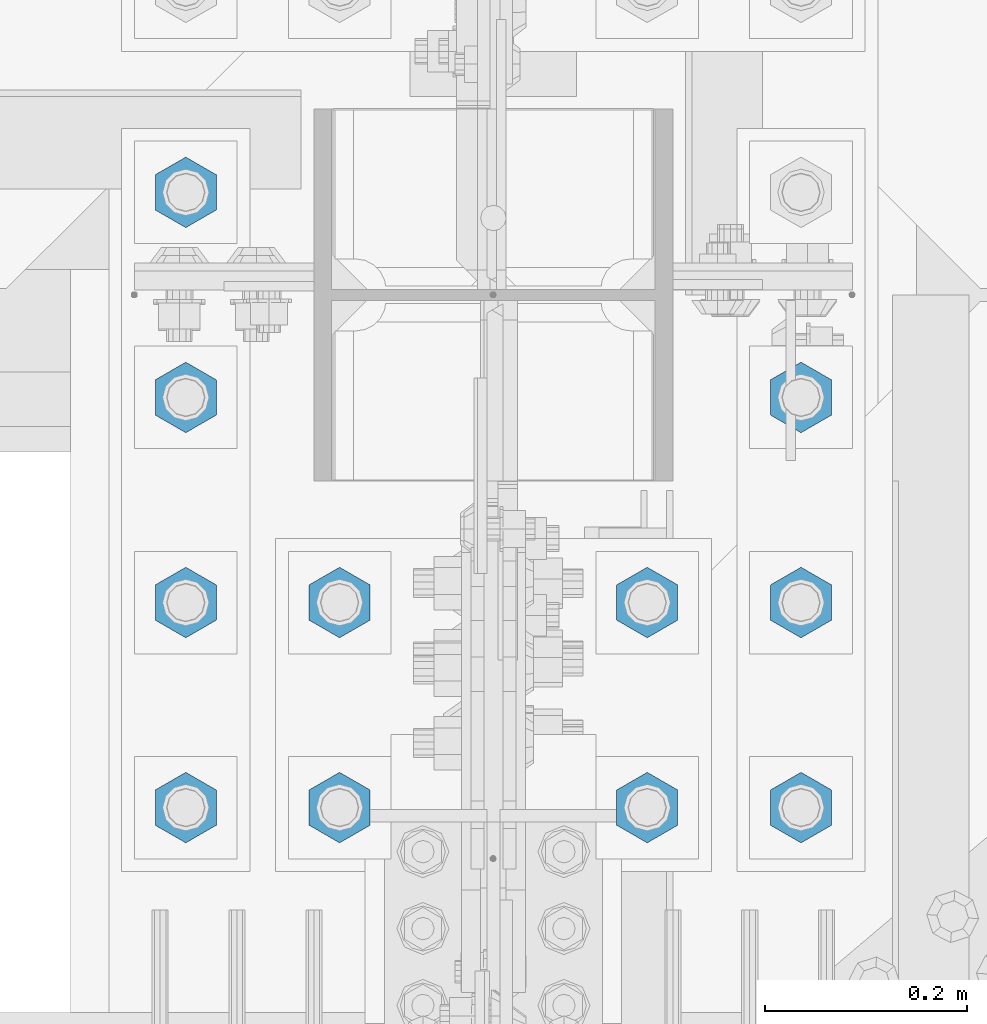
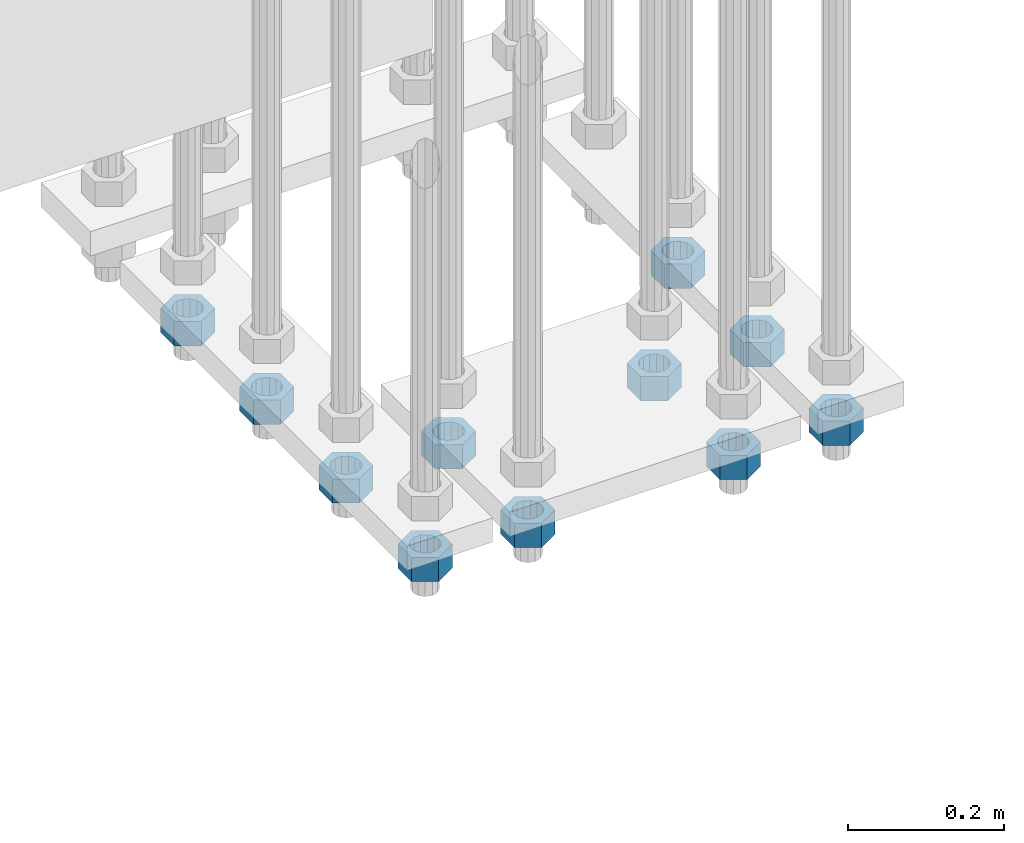
# One storey, part 2841 of 3843: 11 beams, 1 element without a shape of its own.
"""IFC2X3 building model written with IfcOpenShell, lengths in millimetres."""

from ifc_helpers import new_model, si_unit, frame, origin_with_axes, place, context, subcontext, project, spatial, faceted_brep, material, type_object, element, aggregate, save


model = new_model("IFC2X3")

# Units and contexts
model_context = context("Model", 3, precision=1e-05, world=origin_with_axes())
body_context = subcontext(model_context, "Body", "Model", "MODEL_VIEW")
ifc_project = project(units=[si_unit("LENGTHUNIT", "METRE", prefix="MILLI"), si_unit("AREAUNIT", "SQUARE_METRE"), si_unit("VOLUMEUNIT", "CUBIC_METRE"), si_unit("MASSUNIT", "GRAM", prefix="KILO"), si_unit("TIMEUNIT", "SECOND"), si_unit("PLANEANGLEUNIT", "RADIAN"), si_unit("SOLIDANGLEUNIT", "STERADIAN"), si_unit("THERMODYNAMICTEMPERATUREUNIT", "DEGREE_CELSIUS"), si_unit("LUMINOUSINTENSITYUNIT", "LUMEN")], contexts=[model_context])

# Site, building, storey
site_placement = place(None, origin_with_axes())
site = spatial("IfcSite", under=ifc_project, at=site_placement, CompositionType="ELEMENT")
building_placement = place(site_placement, origin_with_axes())
building = spatial("IfcBuilding", under=site, at=building_placement, Name="Undefined", CompositionType="ELEMENT")
storey_placement = place(building_placement, origin_with_axes())
storey = spatial("IfcBuildingStorey", under=building, at=storey_placement, Name="Undefined", CompositionType="ELEMENT", Elevation=0.0)

# Assembly, beams
assembly_placement = place(storey_placement, origin_with_axes())
assembly = element("IfcElementAssembly", 1, at=assembly_placement, inside=storey, Name="TEMPLATE", AssemblyPlace="NOTDEFINED", PredefinedType="RIGID_FRAME")
ifc_material = material(Name="STEEL/A572-50")
beam_type = type_object("IfcBeamType", Name="1-1/2_HEAVY_HEX_NUT", PredefinedType="NOTDEFINED")
beam_1_placement = place(assembly_placement, frame((77317.6, 25514.3, 29203.6500015259), z_axis=(1.0, 0.0, 0.0), x_axis=(0.0, 0.0, -1.0)))
beam_1 = element("IfcBeam", 2, at=beam_1_placement, type_object=beam_type, material=ifc_material, Name="NUT", ObjectType="1-1/2_HEAVY_HEX_NUT", context=body_context, shape_type="Brep", body=[
    faceted_brep([(0.0, -34.9199981689453, 0.0), (0.0, -17.4599990844727, -30.25), (38.0999999999985, -17.4599990844727, -30.25), (38.0999999999985, -34.9199981689453, 0.0), (0.0, 17.4599990844727, -30.25), (38.0999999999985, 17.4599990844727, -30.25), (0.0, 34.9199981689453, 0.0), (38.0999999999985, 34.9199981689453, 0.0), (0.0, 17.4599990844727, 30.25), (38.0999999999985, 17.4599990844727, 30.25), (0.0, -17.4599990844727, 30.25), (38.0999999999985, -17.4599990844727, 30.25), (0.0, 0.0, 20.6399993896484), (0.0, 8.9553601105581, 18.5959968835959), (38.0999999999985, 8.9553601105581, 18.5959968835959), (38.0999999999985, 0.0, 20.6399993896484), (0.0, 16.1370013209525, 12.8688291298167), (38.0999999999985, 16.1370013209525, 12.8688291298167), (0.0, 20.1225115123816, 4.59283194104501), (38.0999999999985, 20.1225115123816, 4.59283194104501), (0.0, 20.1225115123816, -4.59283194104501), (38.0999999999985, 20.1225115123816, -4.59283194104501), (0.0, 16.1370013209525, -12.8688291298167), (38.0999999999985, 16.1370013209525, -12.8688291298167), (0.0, 8.9553601105581, -18.5959968835959), (38.0999999999985, 8.9553601105581, -18.5959968835959), (0.0, 0.0, -20.6399993896484), (38.0999999999985, 0.0, -20.6399993896484), (0.0, -8.9553601105581, -18.5959968835959), (38.0999999999985, -8.9553601105581, -18.5959968835959), (0.0, -16.1370013209525, -12.8688291298167), (38.0999999999985, -16.1370013209525, -12.8688291298167), (0.0, -20.1225115123816, -4.59283194104501), (38.0999999999985, -20.1225115123816, -4.59283194104501), (0.0, -20.1225115123816, 4.59283194104501), (38.0999999999985, -20.1225115123816, 4.59283194104501), (0.0, -16.1370013209525, 12.8688291298167), (38.0999999999985, -16.1370013209525, 12.8688291298167), (0.0, -8.9553601105581, 18.5959968835959), (38.0999999999985, -8.9553601105581, 18.5959968835959)], [[[0, 1, 2, 3]], [[1, 4, 5, 2]], [[4, 6, 7, 5]], [[6, 8, 9, 7]], [[8, 10, 11, 9]], [[10, 0, 3, 11]], [[12, 13, 14, 15]], [[13, 16, 17, 14]], [[16, 18, 19, 17]], [[18, 20, 21, 19]], [[20, 22, 23, 21]], [[22, 24, 25, 23]], [[24, 26, 27, 25]], [[26, 28, 29, 27]], [[28, 30, 31, 29]], [[30, 32, 33, 31]], [[32, 34, 35, 33]], [[34, 36, 37, 35]], [[36, 38, 39, 37]], [[38, 12, 15, 39]], [[5, 7, 9, 11, 3, 2], [17, 19, 21, 23, 25, 27, 29, 31, 33, 35, 37, 39, 15, 14]], [[10, 8, 6, 4, 1, 0], [38, 36, 34, 32, 30, 28, 26, 24, 22, 20, 18, 16, 13, 12]]]),
])
beam_2_placement = place(assembly_placement, frame((77317.6, 25311.1, 29203.6500015259), z_axis=(-1.0, 0.0, 0.0), x_axis=(0.0, 0.0, -1.0)))
beam_2 = element("IfcBeam", 3, at=beam_2_placement, type_object=beam_type, material=ifc_material, Name="NUT", ObjectType="1-1/2_HEAVY_HEX_NUT", context=body_context, shape_type="Brep", body=[
    faceted_brep([(0.0, -34.9199981689453, 0.0), (0.0, -17.4599990844727, -30.25), (38.0999999999985, -17.4599990844727, -30.25), (38.0999999999985, -34.9199981689453, 0.0), (0.0, 17.4599990844727, -30.25), (38.0999999999985, 17.4599990844727, -30.25), (0.0, 34.9199981689453, 0.0), (38.0999999999985, 34.9199981689453, 0.0), (0.0, 17.4599990844727, 30.25), (38.0999999999985, 17.4599990844727, 30.25), (0.0, -17.4599990844727, 30.25), (38.0999999999985, -17.4599990844727, 30.25), (0.0, 0.0, 20.6399993896484), (0.0, 8.9553601105581, 18.5959968835959), (38.0999999999985, 8.9553601105581, 18.5959968835959), (38.0999999999985, 0.0, 20.6399993896484), (0.0, 16.1370013209525, 12.8688291298167), (38.0999999999985, 16.1370013209525, 12.8688291298167), (0.0, 20.1225115123816, 4.59283194104501), (38.0999999999985, 20.1225115123816, 4.59283194104501), (0.0, 20.1225115123816, -4.59283194104501), (38.0999999999985, 20.1225115123816, -4.59283194104501), (0.0, 16.1370013209525, -12.8688291298167), (38.0999999999985, 16.1370013209525, -12.8688291298167), (0.0, 8.9553601105581, -18.5959968835959), (38.0999999999985, 8.9553601105581, -18.5959968835959), (0.0, 0.0, -20.6399993896484), (38.0999999999985, 0.0, -20.6399993896484), (0.0, -8.9553601105581, -18.5959968835959), (38.0999999999985, -8.9553601105581, -18.5959968835959), (0.0, -16.1370013209525, -12.8688291298167), (38.0999999999985, -16.1370013209525, -12.8688291298167), (0.0, -20.1225115123816, -4.59283194104501), (38.0999999999985, -20.1225115123816, -4.59283194104501), (0.0, -20.1225115123816, 4.59283194104501), (38.0999999999985, -20.1225115123816, 4.59283194104501), (0.0, -16.1370013209525, 12.8688291298167), (38.0999999999985, -16.1370013209525, 12.8688291298167), (0.0, -8.9553601105581, 18.5959968835959), (38.0999999999985, -8.9553601105581, 18.5959968835959)], [[[0, 1, 2, 3]], [[1, 4, 5, 2]], [[4, 6, 7, 5]], [[6, 8, 9, 7]], [[8, 10, 11, 9]], [[10, 0, 3, 11]], [[12, 13, 14, 15]], [[13, 16, 17, 14]], [[16, 18, 19, 17]], [[18, 20, 21, 19]], [[20, 22, 23, 21]], [[22, 24, 25, 23]], [[24, 26, 27, 25]], [[26, 28, 29, 27]], [[28, 30, 31, 29]], [[30, 32, 33, 31]], [[32, 34, 35, 33]], [[34, 36, 37, 35]], [[36, 38, 39, 37]], [[38, 12, 15, 39]], [[5, 7, 9, 11, 3, 2], [17, 19, 21, 23, 25, 27, 29, 31, 33, 35, 37, 39, 15, 14]], [[10, 8, 6, 4, 1, 0], [38, 36, 34, 32, 30, 28, 26, 24, 22, 20, 18, 16, 13, 12]]]),
])
beam_3_placement = place(assembly_placement, frame((77317.6, 25107.9, 29203.6500015259), z_axis=(-1.0, 0.0, 0.0), x_axis=(0.0, 0.0, -1.0)))
beam_3 = element("IfcBeam", 4, at=beam_3_placement, type_object=beam_type, material=ifc_material, Name="NUT", ObjectType="1-1/2_HEAVY_HEX_NUT", context=body_context, shape_type="Brep", body=[
    faceted_brep([(0.0, -34.9199981689453, 0.0), (0.0, -17.4599990844727, -30.25), (38.0999999999985, -17.4599990844727, -30.25), (38.0999999999985, -34.9199981689453, 0.0), (0.0, 17.4599990844727, -30.25), (38.0999999999985, 17.4599990844727, -30.25), (0.0, 34.9199981689453, 0.0), (38.0999999999985, 34.9199981689453, 0.0), (0.0, 17.4599990844727, 30.25), (38.0999999999985, 17.4599990844727, 30.25), (0.0, -17.4599990844727, 30.25), (38.0999999999985, -17.4599990844727, 30.25), (0.0, 0.0, 20.6399993896484), (0.0, 8.9553601105581, 18.5959968835959), (38.0999999999985, 8.9553601105581, 18.5959968835959), (38.0999999999985, 0.0, 20.6399993896484), (0.0, 16.1370013209525, 12.8688291298167), (38.0999999999985, 16.1370013209525, 12.8688291298167), (0.0, 20.1225115123816, 4.59283194104501), (38.0999999999985, 20.1225115123816, 4.59283194104501), (0.0, 20.1225115123816, -4.59283194104501), (38.0999999999985, 20.1225115123816, -4.59283194104501), (0.0, 16.1370013209525, -12.8688291298167), (38.0999999999985, 16.1370013209525, -12.8688291298167), (0.0, 8.9553601105581, -18.5959968835959), (38.0999999999985, 8.9553601105581, -18.5959968835959), (0.0, 0.0, -20.6399993896484), (38.0999999999985, 0.0, -20.6399993896484), (0.0, -8.9553601105581, -18.5959968835959), (38.0999999999985, -8.9553601105581, -18.5959968835959), (0.0, -16.1370013209525, -12.8688291298167), (38.0999999999985, -16.1370013209525, -12.8688291298167), (0.0, -20.1225115123816, -4.59283194104501), (38.0999999999985, -20.1225115123816, -4.59283194104501), (0.0, -20.1225115123816, 4.59283194104501), (38.0999999999985, -20.1225115123816, 4.59283194104501), (0.0, -16.1370013209525, 12.8688291298167), (38.0999999999985, -16.1370013209525, 12.8688291298167), (0.0, -8.9553601105581, 18.5959968835959), (38.0999999999985, -8.9553601105581, 18.5959968835959)], [[[0, 1, 2, 3]], [[1, 4, 5, 2]], [[4, 6, 7, 5]], [[6, 8, 9, 7]], [[8, 10, 11, 9]], [[10, 0, 3, 11]], [[12, 13, 14, 15]], [[13, 16, 17, 14]], [[16, 18, 19, 17]], [[18, 20, 21, 19]], [[20, 22, 23, 21]], [[22, 24, 25, 23]], [[24, 26, 27, 25]], [[26, 28, 29, 27]], [[28, 30, 31, 29]], [[30, 32, 33, 31]], [[32, 34, 35, 33]], [[34, 36, 37, 35]], [[36, 38, 39, 37]], [[38, 12, 15, 39]], [[5, 7, 9, 11, 3, 2], [17, 19, 21, 23, 25, 27, 29, 31, 33, 35, 37, 39, 15, 14]], [[10, 8, 6, 4, 1, 0], [38, 36, 34, 32, 30, 28, 26, 24, 22, 20, 18, 16, 13, 12]]]),
])
beam_4_placement = place(assembly_placement, frame((77165.2, 25311.1, 29203.6500015259), z_axis=(-1.0, 0.0, 0.0), x_axis=(0.0, 0.0, -1.0)))
beam_4 = element("IfcBeam", 5, at=beam_4_placement, type_object=beam_type, material=ifc_material, Name="NUT", ObjectType="1-1/2_HEAVY_HEX_NUT", context=body_context, shape_type="Brep", body=[
    faceted_brep([(0.0, -34.9199981689453, 0.0), (0.0, -17.4599990844727, -30.25), (38.0999999999985, -17.4599990844727, -30.25), (38.0999999999985, -34.9199981689453, 0.0), (0.0, 17.4599990844727, -30.25), (38.0999999999985, 17.4599990844727, -30.25), (0.0, 34.9199981689453, 0.0), (38.0999999999985, 34.9199981689453, 0.0), (0.0, 17.4599990844727, 30.25), (38.0999999999985, 17.4599990844727, 30.25), (0.0, -17.4599990844727, 30.25), (38.0999999999985, -17.4599990844727, 30.25), (0.0, 0.0, 20.6399993896484), (0.0, 8.9553601105581, 18.5959968835959), (38.0999999999985, 8.9553601105581, 18.5959968835959), (38.0999999999985, 0.0, 20.6399993896484), (0.0, 16.1370013209525, 12.8688291298167), (38.0999999999985, 16.1370013209525, 12.8688291298167), (0.0, 20.1225115123816, 4.59283194104501), (38.0999999999985, 20.1225115123816, 4.59283194104501), (0.0, 20.1225115123816, -4.59283194104501), (38.0999999999985, 20.1225115123816, -4.59283194104501), (0.0, 16.1370013209525, -12.8688291298167), (38.0999999999985, 16.1370013209525, -12.8688291298167), (0.0, 8.9553601105581, -18.5959968835959), (38.0999999999985, 8.9553601105581, -18.5959968835959), (0.0, 0.0, -20.6399993896484), (38.0999999999985, 0.0, -20.6399993896484), (0.0, -8.9553601105581, -18.5959968835959), (38.0999999999985, -8.9553601105581, -18.5959968835959), (0.0, -16.1370013209525, -12.8688291298167), (38.0999999999985, -16.1370013209525, -12.8688291298167), (0.0, -20.1225115123816, -4.59283194104501), (38.0999999999985, -20.1225115123816, -4.59283194104501), (0.0, -20.1225115123816, 4.59283194104501), (38.0999999999985, -20.1225115123816, 4.59283194104501), (0.0, -16.1370013209525, 12.8688291298167), (38.0999999999985, -16.1370013209525, 12.8688291298167), (0.0, -8.9553601105581, 18.5959968835959), (38.0999999999985, -8.9553601105581, 18.5959968835959)], [[[0, 1, 2, 3]], [[1, 4, 5, 2]], [[4, 6, 7, 5]], [[6, 8, 9, 7]], [[8, 10, 11, 9]], [[10, 0, 3, 11]], [[12, 13, 14, 15]], [[13, 16, 17, 14]], [[16, 18, 19, 17]], [[18, 20, 21, 19]], [[20, 22, 23, 21]], [[22, 24, 25, 23]], [[24, 26, 27, 25]], [[26, 28, 29, 27]], [[28, 30, 31, 29]], [[30, 32, 33, 31]], [[32, 34, 35, 33]], [[34, 36, 37, 35]], [[36, 38, 39, 37]], [[38, 12, 15, 39]], [[5, 7, 9, 11, 3, 2], [17, 19, 21, 23, 25, 27, 29, 31, 33, 35, 37, 39, 15, 14]], [[10, 8, 6, 4, 1, 0], [38, 36, 34, 32, 30, 28, 26, 24, 22, 20, 18, 16, 13, 12]]]),
])
beam_5_placement = place(assembly_placement, frame((77165.2, 25107.9, 29203.6500015259), z_axis=(-1.0, 0.0, 0.0), x_axis=(0.0, 0.0, -1.0)))
beam_5 = element("IfcBeam", 6, at=beam_5_placement, type_object=beam_type, material=ifc_material, Name="NUT", ObjectType="1-1/2_HEAVY_HEX_NUT", context=body_context, shape_type="Brep", body=[
    faceted_brep([(0.0, -34.9199981689453, 0.0), (0.0, -17.4599990844727, -30.25), (38.0999999999985, -17.4599990844727, -30.25), (38.0999999999985, -34.9199981689453, 0.0), (0.0, 17.4599990844727, -30.25), (38.0999999999985, 17.4599990844727, -30.25), (0.0, 34.9199981689453, 0.0), (38.0999999999985, 34.9199981689453, 0.0), (0.0, 17.4599990844727, 30.25), (38.0999999999985, 17.4599990844727, 30.25), (0.0, -17.4599990844727, 30.25), (38.0999999999985, -17.4599990844727, 30.25), (0.0, 0.0, 20.6399993896484), (0.0, 8.9553601105581, 18.5959968835959), (38.0999999999985, 8.9553601105581, 18.5959968835959), (38.0999999999985, 0.0, 20.6399993896484), (0.0, 16.1370013209525, 12.8688291298167), (38.0999999999985, 16.1370013209525, 12.8688291298167), (0.0, 20.1225115123816, 4.59283194104501), (38.0999999999985, 20.1225115123816, 4.59283194104501), (0.0, 20.1225115123816, -4.59283194104501), (38.0999999999985, 20.1225115123816, -4.59283194104501), (0.0, 16.1370013209525, -12.8688291298167), (38.0999999999985, 16.1370013209525, -12.8688291298167), (0.0, 8.9553601105581, -18.5959968835959), (38.0999999999985, 8.9553601105581, -18.5959968835959), (0.0, 0.0, -20.6399993896484), (38.0999999999985, 0.0, -20.6399993896484), (0.0, -8.9553601105581, -18.5959968835959), (38.0999999999985, -8.9553601105581, -18.5959968835959), (0.0, -16.1370013209525, -12.8688291298167), (38.0999999999985, -16.1370013209525, -12.8688291298167), (0.0, -20.1225115123816, -4.59283194104501), (38.0999999999985, -20.1225115123816, -4.59283194104501), (0.0, -20.1225115123816, 4.59283194104501), (38.0999999999985, -20.1225115123816, 4.59283194104501), (0.0, -16.1370013209525, 12.8688291298167), (38.0999999999985, -16.1370013209525, 12.8688291298167), (0.0, -8.9553601105581, 18.5959968835959), (38.0999999999985, -8.9553601105581, 18.5959968835959)], [[[0, 1, 2, 3]], [[1, 4, 5, 2]], [[4, 6, 7, 5]], [[6, 8, 9, 7]], [[8, 10, 11, 9]], [[10, 0, 3, 11]], [[12, 13, 14, 15]], [[13, 16, 17, 14]], [[16, 18, 19, 17]], [[18, 20, 21, 19]], [[20, 22, 23, 21]], [[22, 24, 25, 23]], [[24, 26, 27, 25]], [[26, 28, 29, 27]], [[28, 30, 31, 29]], [[30, 32, 33, 31]], [[32, 34, 35, 33]], [[34, 36, 37, 35]], [[36, 38, 39, 37]], [[38, 12, 15, 39]], [[5, 7, 9, 11, 3, 2], [17, 19, 21, 23, 25, 27, 29, 31, 33, 35, 37, 39, 15, 14]], [[10, 8, 6, 4, 1, 0], [38, 36, 34, 32, 30, 28, 26, 24, 22, 20, 18, 16, 13, 12]]]),
])
beam_6_placement = place(assembly_placement, frame((76860.4, 25311.1, 29203.6500015259), z_axis=(-1.0, 0.0, 0.0), x_axis=(0.0, 0.0, -1.0)))
beam_6 = element("IfcBeam", 7, at=beam_6_placement, type_object=beam_type, material=ifc_material, Name="NUT", ObjectType="1-1/2_HEAVY_HEX_NUT", context=body_context, shape_type="Brep", body=[
    faceted_brep([(0.0, -34.9199981689453, 0.0), (0.0, -17.4599990844727, -30.25), (38.0999999999985, -17.4599990844727, -30.25), (38.0999999999985, -34.9199981689453, 0.0), (0.0, 17.4599990844727, -30.25), (38.0999999999985, 17.4599990844727, -30.25), (0.0, 34.9199981689453, 0.0), (38.0999999999985, 34.9199981689453, 0.0), (0.0, 17.4599990844727, 30.25), (38.0999999999985, 17.4599990844727, 30.25), (0.0, -17.4599990844727, 30.25), (38.0999999999985, -17.4599990844727, 30.25), (0.0, 0.0, 20.6399993896484), (0.0, 8.9553601105581, 18.5959968835959), (38.0999999999985, 8.9553601105581, 18.5959968835959), (38.0999999999985, 0.0, 20.6399993896484), (0.0, 16.1370013209525, 12.8688291298167), (38.0999999999985, 16.1370013209525, 12.8688291298167), (0.0, 20.1225115123816, 4.59283194104501), (38.0999999999985, 20.1225115123816, 4.59283194104501), (0.0, 20.1225115123816, -4.59283194104501), (38.0999999999985, 20.1225115123816, -4.59283194104501), (0.0, 16.1370013209525, -12.8688291298167), (38.0999999999985, 16.1370013209525, -12.8688291298167), (0.0, 8.9553601105581, -18.5959968835959), (38.0999999999985, 8.9553601105581, -18.5959968835959), (0.0, 0.0, -20.6399993896484), (38.0999999999985, 0.0, -20.6399993896484), (0.0, -8.9553601105581, -18.5959968835959), (38.0999999999985, -8.9553601105581, -18.5959968835959), (0.0, -16.1370013209525, -12.8688291298167), (38.0999999999985, -16.1370013209525, -12.8688291298167), (0.0, -20.1225115123816, -4.59283194104501), (38.0999999999985, -20.1225115123816, -4.59283194104501), (0.0, -20.1225115123816, 4.59283194104501), (38.0999999999985, -20.1225115123816, 4.59283194104501), (0.0, -16.1370013209525, 12.8688291298167), (38.0999999999985, -16.1370013209525, 12.8688291298167), (0.0, -8.9553601105581, 18.5959968835959), (38.0999999999985, -8.9553601105581, 18.5959968835959)], [[[0, 1, 2, 3]], [[1, 4, 5, 2]], [[4, 6, 7, 5]], [[6, 8, 9, 7]], [[8, 10, 11, 9]], [[10, 0, 3, 11]], [[12, 13, 14, 15]], [[13, 16, 17, 14]], [[16, 18, 19, 17]], [[18, 20, 21, 19]], [[20, 22, 23, 21]], [[22, 24, 25, 23]], [[24, 26, 27, 25]], [[26, 28, 29, 27]], [[28, 30, 31, 29]], [[30, 32, 33, 31]], [[32, 34, 35, 33]], [[34, 36, 37, 35]], [[36, 38, 39, 37]], [[38, 12, 15, 39]], [[5, 7, 9, 11, 3, 2], [17, 19, 21, 23, 25, 27, 29, 31, 33, 35, 37, 39, 15, 14]], [[10, 8, 6, 4, 1, 0], [38, 36, 34, 32, 30, 28, 26, 24, 22, 20, 18, 16, 13, 12]]]),
])
beam_7_placement = place(assembly_placement, frame((76860.4, 25107.9, 29203.6500015259), z_axis=(-1.0, 0.0, 0.0), x_axis=(0.0, 0.0, -1.0)))
beam_7 = element("IfcBeam", 8, at=beam_7_placement, type_object=beam_type, material=ifc_material, Name="NUT", ObjectType="1-1/2_HEAVY_HEX_NUT", context=body_context, shape_type="Brep", body=[
    faceted_brep([(0.0, -34.9199981689453, 0.0), (0.0, -17.4599990844727, -30.25), (38.0999999999985, -17.4599990844727, -30.25), (38.0999999999985, -34.9199981689453, 0.0), (0.0, 17.4599990844727, -30.25), (38.0999999999985, 17.4599990844727, -30.25), (0.0, 34.9199981689453, 0.0), (38.0999999999985, 34.9199981689453, 0.0), (0.0, 17.4599990844727, 30.25), (38.0999999999985, 17.4599990844727, 30.25), (0.0, -17.4599990844727, 30.25), (38.0999999999985, -17.4599990844727, 30.25), (0.0, 0.0, 20.6399993896484), (0.0, 8.9553601105581, 18.5959968835959), (38.0999999999985, 8.9553601105581, 18.5959968835959), (38.0999999999985, 0.0, 20.6399993896484), (0.0, 16.1370013209525, 12.8688291298167), (38.0999999999985, 16.1370013209525, 12.8688291298167), (0.0, 20.1225115123816, 4.59283194104501), (38.0999999999985, 20.1225115123816, 4.59283194104501), (0.0, 20.1225115123816, -4.59283194104501), (38.0999999999985, 20.1225115123816, -4.59283194104501), (0.0, 16.1370013209525, -12.8688291298167), (38.0999999999985, 16.1370013209525, -12.8688291298167), (0.0, 8.9553601105581, -18.5959968835959), (38.0999999999985, 8.9553601105581, -18.5959968835959), (0.0, 0.0, -20.6399993896484), (38.0999999999985, 0.0, -20.6399993896484), (0.0, -8.9553601105581, -18.5959968835959), (38.0999999999985, -8.9553601105581, -18.5959968835959), (0.0, -16.1370013209525, -12.8688291298167), (38.0999999999985, -16.1370013209525, -12.8688291298167), (0.0, -20.1225115123816, -4.59283194104501), (38.0999999999985, -20.1225115123816, -4.59283194104501), (0.0, -20.1225115123816, 4.59283194104501), (38.0999999999985, -20.1225115123816, 4.59283194104501), (0.0, -16.1370013209525, 12.8688291298167), (38.0999999999985, -16.1370013209525, 12.8688291298167), (0.0, -8.9553601105581, 18.5959968835959), (38.0999999999985, -8.9553601105581, 18.5959968835959)], [[[0, 1, 2, 3]], [[1, 4, 5, 2]], [[4, 6, 7, 5]], [[6, 8, 9, 7]], [[8, 10, 11, 9]], [[10, 0, 3, 11]], [[12, 13, 14, 15]], [[13, 16, 17, 14]], [[16, 18, 19, 17]], [[18, 20, 21, 19]], [[20, 22, 23, 21]], [[22, 24, 25, 23]], [[24, 26, 27, 25]], [[26, 28, 29, 27]], [[28, 30, 31, 29]], [[30, 32, 33, 31]], [[32, 34, 35, 33]], [[34, 36, 37, 35]], [[36, 38, 39, 37]], [[38, 12, 15, 39]], [[5, 7, 9, 11, 3, 2], [17, 19, 21, 23, 25, 27, 29, 31, 33, 35, 37, 39, 15, 14]], [[10, 8, 6, 4, 1, 0], [38, 36, 34, 32, 30, 28, 26, 24, 22, 20, 18, 16, 13, 12]]]),
])
beam_8_placement = place(assembly_placement, frame((76708.0, 25717.5, 29203.6500015259), z_axis=(1.0, 0.0, 0.0), x_axis=(0.0, 0.0, -1.0)))
beam_8 = element("IfcBeam", 9, at=beam_8_placement, type_object=beam_type, material=ifc_material, Name="NUT", ObjectType="1-1/2_HEAVY_HEX_NUT", context=body_context, shape_type="Brep", body=[
    faceted_brep([(0.0, -34.9199981689453, 0.0), (0.0, -17.4599990844727, -30.25), (38.0999999999985, -17.4599990844727, -30.25), (38.0999999999985, -34.9199981689453, 0.0), (0.0, 17.4599990844727, -30.25), (38.0999999999985, 17.4599990844727, -30.25), (0.0, 34.9199981689453, 0.0), (38.0999999999985, 34.9199981689453, 0.0), (0.0, 17.4599990844727, 30.25), (38.0999999999985, 17.4599990844727, 30.25), (0.0, -17.4599990844727, 30.25), (38.0999999999985, -17.4599990844727, 30.25), (0.0, 0.0, 20.6399993896484), (0.0, 8.9553601105581, 18.5959968835959), (38.0999999999985, 8.9553601105581, 18.5959968835959), (38.0999999999985, 0.0, 20.6399993896484), (0.0, 16.1370013209525, 12.8688291298167), (38.0999999999985, 16.1370013209525, 12.8688291298167), (0.0, 20.1225115123816, 4.59283194104501), (38.0999999999985, 20.1225115123816, 4.59283194104501), (0.0, 20.1225115123816, -4.59283194104501), (38.0999999999985, 20.1225115123816, -4.59283194104501), (0.0, 16.1370013209525, -12.8688291298167), (38.0999999999985, 16.1370013209525, -12.8688291298167), (0.0, 8.9553601105581, -18.5959968835959), (38.0999999999985, 8.9553601105581, -18.5959968835959), (0.0, 0.0, -20.6399993896484), (38.0999999999985, 0.0, -20.6399993896484), (0.0, -8.9553601105581, -18.5959968835959), (38.0999999999985, -8.9553601105581, -18.5959968835959), (0.0, -16.1370013209525, -12.8688291298167), (38.0999999999985, -16.1370013209525, -12.8688291298167), (0.0, -20.1225115123816, -4.59283194104501), (38.0999999999985, -20.1225115123816, -4.59283194104501), (0.0, -20.1225115123816, 4.59283194104501), (38.0999999999985, -20.1225115123816, 4.59283194104501), (0.0, -16.1370013209525, 12.8688291298167), (38.0999999999985, -16.1370013209525, 12.8688291298167), (0.0, -8.9553601105581, 18.5959968835959), (38.0999999999985, -8.9553601105581, 18.5959968835959)], [[[0, 1, 2, 3]], [[1, 4, 5, 2]], [[4, 6, 7, 5]], [[6, 8, 9, 7]], [[8, 10, 11, 9]], [[10, 0, 3, 11]], [[12, 13, 14, 15]], [[13, 16, 17, 14]], [[16, 18, 19, 17]], [[18, 20, 21, 19]], [[20, 22, 23, 21]], [[22, 24, 25, 23]], [[24, 26, 27, 25]], [[26, 28, 29, 27]], [[28, 30, 31, 29]], [[30, 32, 33, 31]], [[32, 34, 35, 33]], [[34, 36, 37, 35]], [[36, 38, 39, 37]], [[38, 12, 15, 39]], [[5, 7, 9, 11, 3, 2], [17, 19, 21, 23, 25, 27, 29, 31, 33, 35, 37, 39, 15, 14]], [[10, 8, 6, 4, 1, 0], [38, 36, 34, 32, 30, 28, 26, 24, 22, 20, 18, 16, 13, 12]]]),
])
beam_9_placement = place(assembly_placement, frame((76708.0, 25514.3, 29203.6500015259), z_axis=(1.0, 0.0, 0.0), x_axis=(0.0, 0.0, -1.0)))
beam_9 = element("IfcBeam", 10, at=beam_9_placement, type_object=beam_type, material=ifc_material, Name="NUT", ObjectType="1-1/2_HEAVY_HEX_NUT", context=body_context, shape_type="Brep", body=[
    faceted_brep([(0.0, -34.9199981689453, 0.0), (0.0, -17.4599990844727, -30.25), (38.0999999999985, -17.4599990844727, -30.25), (38.0999999999985, -34.9199981689453, 0.0), (0.0, 17.4599990844727, -30.25), (38.0999999999985, 17.4599990844727, -30.25), (0.0, 34.9199981689453, 0.0), (38.0999999999985, 34.9199981689453, 0.0), (0.0, 17.4599990844727, 30.25), (38.0999999999985, 17.4599990844727, 30.25), (0.0, -17.4599990844727, 30.25), (38.0999999999985, -17.4599990844727, 30.25), (0.0, 0.0, 20.6399993896484), (0.0, 8.9553601105581, 18.5959968835959), (38.0999999999985, 8.9553601105581, 18.5959968835959), (38.0999999999985, 0.0, 20.6399993896484), (0.0, 16.1370013209525, 12.8688291298167), (38.0999999999985, 16.1370013209525, 12.8688291298167), (0.0, 20.1225115123816, 4.59283194104501), (38.0999999999985, 20.1225115123816, 4.59283194104501), (0.0, 20.1225115123816, -4.59283194104501), (38.0999999999985, 20.1225115123816, -4.59283194104501), (0.0, 16.1370013209525, -12.8688291298167), (38.0999999999985, 16.1370013209525, -12.8688291298167), (0.0, 8.9553601105581, -18.5959968835959), (38.0999999999985, 8.9553601105581, -18.5959968835959), (0.0, 0.0, -20.6399993896484), (38.0999999999985, 0.0, -20.6399993896484), (0.0, -8.9553601105581, -18.5959968835959), (38.0999999999985, -8.9553601105581, -18.5959968835959), (0.0, -16.1370013209525, -12.8688291298167), (38.0999999999985, -16.1370013209525, -12.8688291298167), (0.0, -20.1225115123816, -4.59283194104501), (38.0999999999985, -20.1225115123816, -4.59283194104501), (0.0, -20.1225115123816, 4.59283194104501), (38.0999999999985, -20.1225115123816, 4.59283194104501), (0.0, -16.1370013209525, 12.8688291298167), (38.0999999999985, -16.1370013209525, 12.8688291298167), (0.0, -8.9553601105581, 18.5959968835959), (38.0999999999985, -8.9553601105581, 18.5959968835959)], [[[0, 1, 2, 3]], [[1, 4, 5, 2]], [[4, 6, 7, 5]], [[6, 8, 9, 7]], [[8, 10, 11, 9]], [[10, 0, 3, 11]], [[12, 13, 14, 15]], [[13, 16, 17, 14]], [[16, 18, 19, 17]], [[18, 20, 21, 19]], [[20, 22, 23, 21]], [[22, 24, 25, 23]], [[24, 26, 27, 25]], [[26, 28, 29, 27]], [[28, 30, 31, 29]], [[30, 32, 33, 31]], [[32, 34, 35, 33]], [[34, 36, 37, 35]], [[36, 38, 39, 37]], [[38, 12, 15, 39]], [[5, 7, 9, 11, 3, 2], [17, 19, 21, 23, 25, 27, 29, 31, 33, 35, 37, 39, 15, 14]], [[10, 8, 6, 4, 1, 0], [38, 36, 34, 32, 30, 28, 26, 24, 22, 20, 18, 16, 13, 12]]]),
])
beam_10_placement = place(assembly_placement, frame((76708.0, 25311.1, 29203.6500015259), z_axis=(-1.0, 0.0, 0.0), x_axis=(0.0, 0.0, -1.0)))
beam_10 = element("IfcBeam", 11, at=beam_10_placement, type_object=beam_type, material=ifc_material, Name="NUT", ObjectType="1-1/2_HEAVY_HEX_NUT", context=body_context, shape_type="Brep", body=[
    faceted_brep([(0.0, -34.9199981689453, 0.0), (0.0, -17.4599990844727, -30.25), (38.0999999999985, -17.4599990844727, -30.25), (38.0999999999985, -34.9199981689453, 0.0), (0.0, 17.4599990844727, -30.25), (38.0999999999985, 17.4599990844727, -30.25), (0.0, 34.9199981689453, 0.0), (38.0999999999985, 34.9199981689453, 0.0), (0.0, 17.4599990844727, 30.25), (38.0999999999985, 17.4599990844727, 30.25), (0.0, -17.4599990844727, 30.25), (38.0999999999985, -17.4599990844727, 30.25), (0.0, 0.0, 20.6399993896484), (0.0, 8.9553601105581, 18.5959968835959), (38.0999999999985, 8.9553601105581, 18.5959968835959), (38.0999999999985, 0.0, 20.6399993896484), (0.0, 16.1370013209525, 12.8688291298167), (38.0999999999985, 16.1370013209525, 12.8688291298167), (0.0, 20.1225115123816, 4.59283194104501), (38.0999999999985, 20.1225115123816, 4.59283194104501), (0.0, 20.1225115123816, -4.59283194104501), (38.0999999999985, 20.1225115123816, -4.59283194104501), (0.0, 16.1370013209525, -12.8688291298167), (38.0999999999985, 16.1370013209525, -12.8688291298167), (0.0, 8.9553601105581, -18.5959968835959), (38.0999999999985, 8.9553601105581, -18.5959968835959), (0.0, 0.0, -20.6399993896484), (38.0999999999985, 0.0, -20.6399993896484), (0.0, -8.9553601105581, -18.5959968835959), (38.0999999999985, -8.9553601105581, -18.5959968835959), (0.0, -16.1370013209525, -12.8688291298167), (38.0999999999985, -16.1370013209525, -12.8688291298167), (0.0, -20.1225115123816, -4.59283194104501), (38.0999999999985, -20.1225115123816, -4.59283194104501), (0.0, -20.1225115123816, 4.59283194104501), (38.0999999999985, -20.1225115123816, 4.59283194104501), (0.0, -16.1370013209525, 12.8688291298167), (38.0999999999985, -16.1370013209525, 12.8688291298167), (0.0, -8.9553601105581, 18.5959968835959), (38.0999999999985, -8.9553601105581, 18.5959968835959)], [[[0, 1, 2, 3]], [[1, 4, 5, 2]], [[4, 6, 7, 5]], [[6, 8, 9, 7]], [[8, 10, 11, 9]], [[10, 0, 3, 11]], [[12, 13, 14, 15]], [[13, 16, 17, 14]], [[16, 18, 19, 17]], [[18, 20, 21, 19]], [[20, 22, 23, 21]], [[22, 24, 25, 23]], [[24, 26, 27, 25]], [[26, 28, 29, 27]], [[28, 30, 31, 29]], [[30, 32, 33, 31]], [[32, 34, 35, 33]], [[34, 36, 37, 35]], [[36, 38, 39, 37]], [[38, 12, 15, 39]], [[5, 7, 9, 11, 3, 2], [17, 19, 21, 23, 25, 27, 29, 31, 33, 35, 37, 39, 15, 14]], [[10, 8, 6, 4, 1, 0], [38, 36, 34, 32, 30, 28, 26, 24, 22, 20, 18, 16, 13, 12]]]),
])
beam_11_placement = place(assembly_placement, frame((76708.0, 25107.9, 29203.6500015259), z_axis=(-1.0, 0.0, 0.0), x_axis=(0.0, 0.0, -1.0)))
beam_11 = element("IfcBeam", 12, at=beam_11_placement, type_object=beam_type, material=ifc_material, Name="NUT", ObjectType="1-1/2_HEAVY_HEX_NUT", context=body_context, shape_type="Brep", body=[
    faceted_brep([(0.0, -34.9199981689453, 0.0), (0.0, -17.4599990844727, -30.25), (38.0999999999985, -17.4599990844727, -30.25), (38.0999999999985, -34.9199981689453, 0.0), (0.0, 17.4599990844727, -30.25), (38.0999999999985, 17.4599990844727, -30.25), (0.0, 34.9199981689453, 0.0), (38.0999999999985, 34.9199981689453, 0.0), (0.0, 17.4599990844727, 30.25), (38.0999999999985, 17.4599990844727, 30.25), (0.0, -17.4599990844727, 30.25), (38.0999999999985, -17.4599990844727, 30.25), (0.0, 0.0, 20.6399993896484), (0.0, 8.9553601105581, 18.5959968835959), (38.0999999999985, 8.9553601105581, 18.5959968835959), (38.0999999999985, 0.0, 20.6399993896484), (0.0, 16.1370013209525, 12.8688291298167), (38.0999999999985, 16.1370013209525, 12.8688291298167), (0.0, 20.1225115123816, 4.59283194104501), (38.0999999999985, 20.1225115123816, 4.59283194104501), (0.0, 20.1225115123816, -4.59283194104501), (38.0999999999985, 20.1225115123816, -4.59283194104501), (0.0, 16.1370013209525, -12.8688291298167), (38.0999999999985, 16.1370013209525, -12.8688291298167), (0.0, 8.9553601105581, -18.5959968835959), (38.0999999999985, 8.9553601105581, -18.5959968835959), (0.0, 0.0, -20.6399993896484), (38.0999999999985, 0.0, -20.6399993896484), (0.0, -8.9553601105581, -18.5959968835959), (38.0999999999985, -8.9553601105581, -18.5959968835959), (0.0, -16.1370013209525, -12.8688291298167), (38.0999999999985, -16.1370013209525, -12.8688291298167), (0.0, -20.1225115123816, -4.59283194104501), (38.0999999999985, -20.1225115123816, -4.59283194104501), (0.0, -20.1225115123816, 4.59283194104501), (38.0999999999985, -20.1225115123816, 4.59283194104501), (0.0, -16.1370013209525, 12.8688291298167), (38.0999999999985, -16.1370013209525, 12.8688291298167), (0.0, -8.9553601105581, 18.5959968835959), (38.0999999999985, -8.9553601105581, 18.5959968835959)], [[[0, 1, 2, 3]], [[1, 4, 5, 2]], [[4, 6, 7, 5]], [[6, 8, 9, 7]], [[8, 10, 11, 9]], [[10, 0, 3, 11]], [[12, 13, 14, 15]], [[13, 16, 17, 14]], [[16, 18, 19, 17]], [[18, 20, 21, 19]], [[20, 22, 23, 21]], [[22, 24, 25, 23]], [[24, 26, 27, 25]], [[26, 28, 29, 27]], [[28, 30, 31, 29]], [[30, 32, 33, 31]], [[32, 34, 35, 33]], [[34, 36, 37, 35]], [[36, 38, 39, 37]], [[38, 12, 15, 39]], [[5, 7, 9, 11, 3, 2], [17, 19, 21, 23, 25, 27, 29, 31, 33, 35, 37, 39, 15, 14]], [[10, 8, 6, 4, 1, 0], [38, 36, 34, 32, 30, 28, 26, 24, 22, 20, 18, 16, 13, 12]]]),
])
aggregate(assembly, [beam_1, beam_2, beam_3, beam_4, beam_5, beam_6, beam_7, beam_8, beam_9, beam_10, beam_11])

save(model, "model.ifc")
